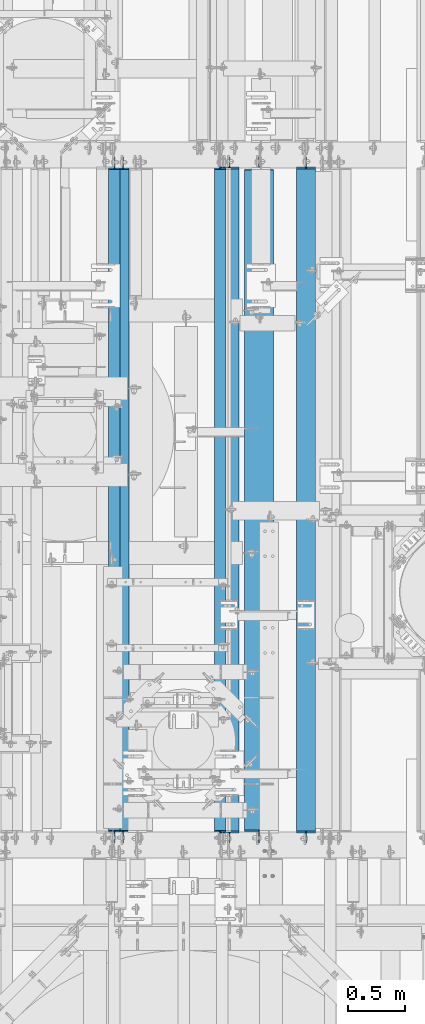
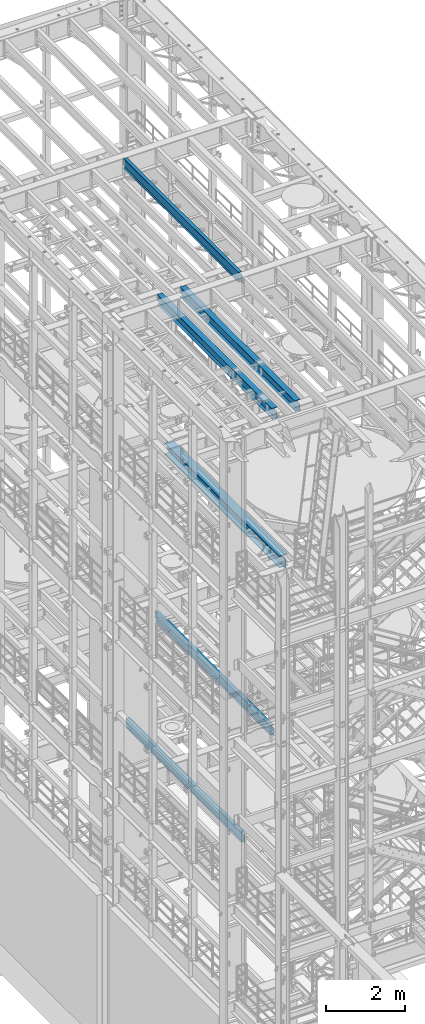
# One storey, part 1030 of 1876: 6 beams, 6 elements without a shape of their own.
"""IFC2X3 building model written with IfcOpenShell, lengths in millimetres."""

from ifc_helpers import new_model, si_unit, frame, origin_with_axes, place, context, subcontext, project, spatial, faceted_brep, material, type_object, element, aggregate, save


model = new_model("IFC2X3")

# Units and contexts
model_context = context("Model", 3, precision=1e-05, world=origin_with_axes())
body_context = subcontext(model_context, "Body", "Model", "MODEL_VIEW")
ifc_project = project(units=[si_unit("LENGTHUNIT", "METRE", prefix="MILLI"), si_unit("AREAUNIT", "SQUARE_METRE"), si_unit("VOLUMEUNIT", "CUBIC_METRE"), si_unit("MASSUNIT", "GRAM", prefix="KILO"), si_unit("TIMEUNIT", "SECOND"), si_unit("PLANEANGLEUNIT", "RADIAN"), si_unit("SOLIDANGLEUNIT", "STERADIAN"), si_unit("THERMODYNAMICTEMPERATUREUNIT", "DEGREE_CELSIUS"), si_unit("LUMINOUSINTENSITYUNIT", "LUMEN")], contexts=[model_context])

# Site, building, storey
site_placement = place(None, origin_with_axes())
site = spatial("IfcSite", under=ifc_project, at=site_placement, CompositionType="ELEMENT")
building_placement = place(site_placement, origin_with_axes())
building = spatial("IfcBuilding", under=site, at=building_placement, Name="Undefined", CompositionType="ELEMENT")
storey_placement = place(building_placement, origin_with_axes())
storey = spatial("IfcBuildingStorey", under=building, at=storey_placement, Name="Undefined", CompositionType="ELEMENT", Elevation=0.0)

# Assembly, beam
assembly_1_placement = place(storey_placement, origin_with_axes())
assembly_1 = element("IfcElementAssembly", 1, at=assembly_1_placement, inside=storey, Name="BEAM", AssemblyPlace="NOTDEFINED", PredefinedType="RIGID_FRAME")
ifc_material = material(Name="STEEL/A992")
beam_type_1 = type_object("IfcBeamType", Name="W12X26", PredefinedType="NOTDEFINED")
beam_1_placement = place(assembly_1_placement, frame((4826.0, 1524.0, 17827.625), z_axis=(0.0, 0.0, 1.0), x_axis=(0.0, 1.0, 0.0)))
beam_1 = element("IfcBeam", 2, at=beam_1_placement, type_object=beam_type_1, material=ifc_material, Name="BEAM", ObjectType="W12X26", context=body_context, shape_type="Brep", body=[
    faceted_brep([(19.8437512414296, -3.17500000000109, -130.175), (19.8437487585795, 3.17499999999927, -130.175), (96.0437824675421, 3.175000000002, -130.175), (96.0437824675423, -3.17499999999745, -130.175), (100.903861985588, 3.175000000002, -131.141729922588), (100.903861985589, -3.17499999999745, -131.141729922588), (105.024038453743, 3.17500000000291, -133.894743823066), (105.024038453744, -3.17499999999654, -133.894743823066), (107.777052354222, 3.17500000000291, -138.01492029122), (107.777052354222, -3.17499999999745, -138.01492029122), (108.743782276811, -3.17499999999654, -142.874999809265), (108.74378227681, 3.17500000000291, -142.874999809265), (108.74375, 3.17500009516311, -146.049999999999), (108.743782276807, 82.5500000000084, -146.05), (108.743782276807, 82.5500000000084, -155.575), (108.743782276814, -82.5500000000029, -155.575), (108.743782276814, -82.5500000000029, -146.05), (108.74375, -3.17499999999995, -146.049999999999), (5969.79375, 82.55, 146.049999999999), (5969.79375, 3.17499999999995, 146.049999999999), (126.20625, 3.17499999999995, 146.049999999999), (126.20625, 82.55, 146.049999999999), (113.506250190735, -3.17499999999995, 111.125000000004), (113.506250190735, 3.17499998562812, 111.125000000004), (19.8437500000002, 3.17499999999995, 111.125000000004), (19.8437500000002, -3.17499999999995, 111.125000000004), (118.36632970878, -3.17499999999995, 112.091729922591), (118.36632970878, 3.17499998547237, 112.091729922591), (122.486506176934, -3.17499999999995, 114.844743823069), (122.486506176934, 3.17499998502694, 114.844743823069), (125.239520077412, -3.17499999999995, 118.964920291222), (125.239520077412, 3.17499998436006, 118.964920291222), (126.20625, -3.17499999999995, 123.824999809269), (126.20625, 3.17499998357312, 123.824999809269), (5969.79375, -82.55, 155.575000000001), (5969.79375, 82.55, 155.575000000001), (126.20625, 82.55, 155.575000000001), (126.20625, -82.55, 155.575000000001), (5969.79375, -82.55, 146.049999999999), (126.20625, -82.55, 146.049999999999), (5969.79375, -3.17499999999995, 146.049999999999), (126.20625, -3.17499999999995, 146.049999999999), (5969.79375, -3.17499999999995, 123.824999809269), (5969.79375, 3.17499999999995, 123.824999809269), (5970.76047992259, -3.17499999999995, 118.964920291222), (5970.76047992259, 3.17499999999995, 118.964920291222), (5973.51349382307, -3.17499999999995, 114.844743823069), (5973.51349382307, 3.17499999999995, 114.844743823069), (5977.63367029122, -3.17499999999995, 112.091729922591), (5977.63367029122, 3.17499999999995, 112.091729922591), (5982.49374980926, -3.17499999999995, 111.125000000004), (5982.49374980926, 3.17499999999995, 111.125000000004), (6076.15625, -3.17499999999995, 111.125000000004), (6076.15625, 3.17499999999995, 111.125000000004), (6076.15625, -3.17499999999995, -130.174999999996), (6076.15625, 3.17499999999995, -130.174999999996), (5999.95624980927, -3.17499999999995, -130.174999999996), (5999.95624980927, 3.17499999999995, -130.174999999996), (5995.09617029122, -3.17499999999995, -131.141729922583), (5995.09617029122, 3.17499999999995, -131.141729922583), (5990.97599382307, -3.17499999999995, -133.894743823061), (5990.97599382307, 3.17499999999995, -133.894743823061), (5988.22297992259, -3.17499999999995, -138.014920291214), (5988.22297992259, 3.17499999999995, -138.014920291214), (5987.25625, -3.17499999999995, -142.874999809261), (5987.25625, 3.17499999999995, -142.874999809261), (5987.25625, -3.17499999999995, -146.049999999999), (5987.25625, -82.55, -146.049999999999), (5987.25625, -82.55, -155.575000000001), (5987.25625, 82.55, -155.575000000001), (5987.25625, 82.55, -146.049999999999), (5987.25625, 3.17499999999995, -146.049999999999)], [[[0, 1, 2, 3]], [[3, 2, 4, 5]], [[5, 4, 6, 7]], [[7, 6, 8, 9]], [[10, 11, 12, 13, 14, 15, 16, 17]], [[9, 8, 11, 10]], [[18, 19, 20, 21]], [[22, 23, 24, 25]], [[26, 27, 23, 22]], [[28, 29, 27, 26]], [[30, 31, 29, 28]], [[32, 33, 31, 30]], [[34, 35, 36, 37]], [[38, 34, 37, 39]], [[40, 38, 39, 41]], [[37, 36, 21, 20, 33, 32, 41, 39]], [[35, 18, 21, 36]], [[34, 38, 40, 42, 43, 19, 18, 35]], [[44, 45, 43, 42]], [[46, 47, 45, 44]], [[48, 49, 47, 46]], [[50, 51, 49, 48]], [[52, 53, 51, 50]], [[53, 52, 54, 55]], [[54, 56, 57, 55]], [[58, 59, 57, 56]], [[60, 61, 59, 58]], [[62, 63, 61, 60]], [[64, 65, 63, 62]], [[66, 67, 68, 69, 70, 71, 65, 64]], [[67, 66, 17, 16]], [[68, 67, 16, 15]], [[69, 68, 15, 14]], [[70, 69, 14, 13]], [[71, 70, 13, 12]], [[6, 4, 2, 1, 24, 23, 27, 29, 31, 33, 20, 19, 43, 45, 47, 49, 51, 53, 55, 57, 59, 61, 63, 65, 71, 12, 11, 8]], [[25, 24, 1, 0]], [[66, 64, 62, 60, 58, 56, 54, 52, 50, 48, 46, 44, 42, 40, 41, 32, 30, 28, 26, 22, 25, 0, 3, 5, 7, 9, 10, 17]]]),
])
aggregate(assembly_1, [beam_1])

assembly_2_placement = place(storey_placement, origin_with_axes())
assembly_2 = element("IfcElementAssembly", 3, at=assembly_2_placement, inside=storey, Name="BEAM", AssemblyPlace="NOTDEFINED", PredefinedType="RIGID_FRAME")
beam_type_2 = type_object("IfcBeamType", Name="W12X16", PredefinedType="NOTDEFINED")
beam_2_placement = place(assembly_2_placement, frame((4743.45, 1524.0, 8001.0), z_axis=(0.0, 0.0, 1.0), x_axis=(0.0, 1.0, 0.0)))
beam_2 = element("IfcBeam", 4, at=beam_2_placement, type_object=beam_type_2, material=ifc_material, Name="BEAM", ObjectType="W12X16", context=body_context, shape_type="Brep", body=[
    faceted_brep([(5980.90625, -3.17499999999995, -146.05), (5980.90625, -50.8, -146.05), (5980.90625, -50.8, -152.4), (5980.90625, 50.8, -152.4), (5980.90625, 50.8, -146.05), (5980.90625, 3.17499999999995, -146.05), (5980.90625, 3.17499999999995, -139.699999809266), (5980.90625, -3.17499999999995, -139.699999809266), (5981.87297992259, 3.17499999999995, -134.839920291221), (5981.87297992259, -3.17499999999995, -134.839920291221), (5984.62599382307, 3.17499999999995, -130.719743823067), (5984.62599382307, -3.17499999999995, -130.719743823067), (5988.74617029122, 3.17499999999995, -127.966729922588), (5988.74617029122, -3.17499999999995, -127.966729922588), (5993.60624980927, 3.17499999999995, -127.000000000001), (5993.60624980927, -3.17499999999995, -127.000000000001), (6076.15625, -3.17499999999995, -126.999999999996), (6076.15625, 3.17499999999995, -126.999999999996), (127.79375, 3.17500000000018, 146.05), (127.79375, 50.8000000000002, 146.05), (5968.20625, 50.8, 146.05), (5968.20625, 3.17499999999995, 146.05), (115.09375, -3.17500000000018, -139.699999809266), (115.09375, 3.17500000000018, -139.699999809266), (115.09375, 3.17500000000018, -146.05), (115.09375, 50.8000000000002, -146.05), (115.09375, 50.8000000000002, -152.4), (115.09375, -50.8000000000002, -152.4), (115.09375, -50.8000000000002, -146.05), (115.09375, -3.17500000000018, -146.05), (114.127020077412, -3.17500000000018, -134.839920291221), (114.127020077412, 3.17500000000018, -134.839920291221), (111.374006176934, -3.17500000000018, -130.719743823067), (111.374006176934, 3.17500000000018, -130.719743823067), (107.25382970878, -3.17500000000018, -127.966729922588), (107.25382970878, 3.17500000000018, -127.966729922588), (102.393750190735, -3.17500000000018, -127.000000000001), (102.393750190735, 3.17500000000018, -127.000000000001), (19.84375, -3.17499999999995, -126.999999999996), (19.84375, 3.17499999999995, -126.999999999996), (19.84375, -3.17500000000018, 114.299999999999), (19.84375, 3.17500000000018, 114.299999999999), (115.093750190735, -3.17500000000018, 114.299999999999), (115.093750190735, 3.17500000000018, 114.299999999999), (119.95382970878, -3.17500000000018, 115.266729922587), (119.95382970878, 3.17500000000018, 115.266729922587), (124.074006176934, -3.17500000000018, 118.019743823065), (124.074006176934, 3.17500000000018, 118.019743823065), (126.827020077412, -3.17500000000018, 122.139920291219), (126.827020077412, 3.17500000000018, 122.139920291219), (127.79375, -3.17500000000018, 126.999999809264), (127.79375, 3.17500000000018, 126.999999809264), (127.79375, -50.8000000000002, 152.4), (127.79375, 50.8000000000002, 152.4), (127.79375, -3.17500000000018, 146.05), (127.79375, -50.8000000000002, 146.05), (5968.20625, -3.17499999999995, 146.05), (5968.20625, -50.8, 146.05), (5968.20625, -50.8, 152.4), (5968.20625, 50.8, 152.4), (5968.20625, -3.17499999999995, 126.999999809264), (5968.20625, 3.17499999999995, 126.999999809264), (5969.17297992259, -3.17499999999995, 122.139920291219), (5969.17297992259, 3.17499999999995, 122.139920291219), (5971.92599382307, -3.17499999999995, 118.019743823065), (5971.92599382307, 3.17499999999995, 118.019743823065), (5976.04617029122, -3.17499999999995, 115.266729922587), (5976.04617029122, 3.17499999999995, 115.266729922587), (5980.90624980927, -3.17499999999995, 114.299999999999), (5980.90624980927, 3.17499999999995, 114.299999999999), (6076.15625, -3.17499999999995, 114.299999999999), (6076.15625, 3.17499999999995, 114.299999999999)], [[[0, 1, 2, 3, 4, 5, 6, 7]], [[7, 6, 8, 9]], [[9, 8, 10, 11]], [[11, 10, 12, 13]], [[13, 12, 14, 15]], [[16, 15, 14, 17]], [[18, 19, 20, 21]], [[22, 23, 24, 25, 26, 27, 28, 29]], [[30, 31, 23, 22]], [[32, 33, 31, 30]], [[34, 35, 33, 32]], [[36, 37, 35, 34]], [[38, 39, 37, 36]], [[40, 41, 39, 38]], [[42, 43, 41, 40]], [[44, 45, 43, 42]], [[46, 47, 45, 44]], [[48, 49, 47, 46]], [[50, 51, 49, 48]], [[52, 53, 19, 18, 51, 50, 54, 55]], [[55, 54, 56, 57]], [[52, 55, 57, 58]], [[53, 52, 58, 59]], [[19, 53, 59, 20]], [[58, 57, 56, 60, 61, 21, 20, 59]], [[62, 63, 61, 60]], [[64, 65, 63, 62]], [[66, 67, 65, 64]], [[68, 69, 67, 66]], [[70, 71, 69, 68]], [[71, 70, 16, 17]], [[12, 10, 8, 6, 5, 24, 23, 31, 33, 35, 37, 39, 41, 43, 45, 47, 49, 51, 18, 21, 61, 63, 65, 67, 69, 71, 17, 14]], [[25, 24, 5, 4]], [[26, 25, 4, 3]], [[27, 26, 3, 2]], [[28, 27, 2, 1]], [[29, 28, 1, 0]], [[70, 68, 66, 64, 62, 60, 56, 54, 50, 48, 46, 44, 42, 40, 38, 36, 34, 32, 30, 22, 29, 0, 7, 9, 11, 13, 15, 16]]]),
])
aggregate(assembly_2, [beam_2])

assembly_3_placement = place(storey_placement, origin_with_axes())
assembly_3 = element("IfcElementAssembly", 5, at=assembly_3_placement, inside=storey, Name="BEAM", AssemblyPlace="NOTDEFINED", PredefinedType="RIGID_FRAME")
beam_3_placement = place(assembly_3_placement, frame((3810.0, 1524.0, 22402.8), z_axis=(0.0, 0.0, 1.0), x_axis=(0.0, 1.0, 0.0)))
beam_3 = element("IfcBeam", 6, at=beam_3_placement, type_object=beam_type_2, material=ifc_material, Name="BEAM", ObjectType="W12X16", context=body_context, shape_type="Brep", body=[
    faceted_brep([(19.84375, -3.17499999999995, -126.999999999996), (19.84375, 3.17499999999995, -126.999999999996), (102.393750190735, 3.17500000000018, -127.000000000001), (102.393750190735, -3.17500000000018, -127.000000000001), (107.25382970878, 3.17500000000018, -127.966729922588), (107.25382970878, -3.17500000000018, -127.966729922588), (111.374006176934, 3.17500000000018, -130.719743823067), (111.374006176934, -3.17500000000018, -130.719743823067), (114.127020077412, 3.17500000000018, -134.839920291221), (114.127020077412, -3.17500000000018, -134.839920291221), (115.09375, -3.17500000000018, -139.699999809266), (115.09375, 3.17500000000018, -139.699999809266), (115.09375, 3.17500000000018, -146.05), (115.09375, 50.8000000000002, -146.05), (115.09375, 50.8000000000002, -152.4), (115.09375, -50.8000000000002, -152.4), (115.09375, -50.8000000000002, -146.05), (115.09375, -3.17500000000018, -146.05), (127.79375, 3.17500000000018, 146.05), (127.79375, 50.8000000000002, 146.05), (5968.20625, 50.8, 146.05), (5968.20625, 3.17499999999995, 146.05), (115.093750190735, -3.17500000000018, 114.299999999999), (115.093750190735, 3.17500000000018, 114.299999999999), (19.84375, 3.17500000000018, 114.299999999999), (19.84375, -3.17500000000018, 114.299999999999), (119.95382970878, -3.17500000000018, 115.266729922587), (119.95382970878, 3.17500000000018, 115.266729922587), (124.074006176934, -3.17500000000018, 118.019743823065), (124.074006176934, 3.17500000000018, 118.019743823065), (126.827020077412, -3.17500000000018, 122.139920291219), (126.827020077412, 3.17500000000018, 122.139920291219), (127.79375, -3.17500000000018, 126.999999809264), (127.79375, 3.17500000000018, 126.999999809264), (127.79375, 50.8000000000002, 152.4), (127.79375, -50.8000000000002, 152.4), (5968.20625, -50.8, 152.4), (5968.20625, 50.8, 152.4), (127.79375, -50.8000000000002, 146.05), (5968.20625, -50.8, 146.05), (127.79375, -3.17500000000018, 146.05), (5968.20625, -3.17499999999995, 146.05), (5968.20625, -3.17499999999995, 126.999999809264), (5968.20625, 3.17499999999995, 126.999999809264), (5969.17297992259, -3.17499999999995, 122.139920291219), (5969.17297992259, 3.17499999999995, 122.139920291219), (5971.92599382307, -3.17499999999995, 118.019743823065), (5971.92599382307, 3.17499999999995, 118.019743823065), (5976.04617029122, -3.17499999999995, 115.266729922587), (5976.04617029122, 3.17499999999995, 115.266729922587), (5980.90624980927, -3.17499999999995, 114.299999999999), (5980.90624980927, 3.17499999999995, 114.299999999999), (6076.15625, -3.17499999999995, 114.299999999999), (6076.15625, 3.17499999999995, 114.299999999999), (6076.15625, -3.17499999999995, -126.999999999996), (6076.15625, 3.17499999999995, -126.999999999996), (5993.60624980927, -3.17499999999995, -127.000000000001), (5993.60624980927, 3.17499999999995, -127.000000000001), (5988.74617029122, -3.17499999999995, -127.966729922588), (5988.74617029122, 3.17499999999995, -127.966729922588), (5984.62599382307, -3.17499999999995, -130.719743823067), (5984.62599382307, 3.17499999999995, -130.719743823067), (5981.87297992259, -3.17499999999995, -134.839920291221), (5981.87297992259, 3.17499999999995, -134.839920291221), (5980.90625, -3.17499999999995, -139.699999809266), (5980.90625, 3.17499999999995, -139.699999809266), (5980.90625, -3.17499999999995, -146.05), (5980.90625, -50.8, -146.05), (5980.90625, -50.8, -152.4), (5980.90625, 50.8, -152.4), (5980.90625, 50.8, -146.05), (5980.90625, 3.17499999999995, -146.05)], [[[0, 1, 2, 3]], [[3, 2, 4, 5]], [[5, 4, 6, 7]], [[7, 6, 8, 9]], [[10, 11, 12, 13, 14, 15, 16, 17]], [[9, 8, 11, 10]], [[18, 19, 20, 21]], [[22, 23, 24, 25]], [[26, 27, 23, 22]], [[28, 29, 27, 26]], [[30, 31, 29, 28]], [[32, 33, 31, 30]], [[34, 35, 36, 37]], [[35, 38, 39, 36]], [[38, 40, 41, 39]], [[35, 34, 19, 18, 33, 32, 40, 38]], [[19, 34, 37, 20]], [[36, 39, 41, 42, 43, 21, 20, 37]], [[44, 45, 43, 42]], [[46, 47, 45, 44]], [[48, 49, 47, 46]], [[50, 51, 49, 48]], [[52, 53, 51, 50]], [[53, 52, 54, 55]], [[54, 56, 57, 55]], [[58, 59, 57, 56]], [[60, 61, 59, 58]], [[62, 63, 61, 60]], [[64, 65, 63, 62]], [[66, 67, 68, 69, 70, 71, 65, 64]], [[17, 16, 67, 66]], [[16, 15, 68, 67]], [[15, 14, 69, 68]], [[14, 13, 70, 69]], [[13, 12, 71, 70]], [[59, 61, 63, 65, 71, 12, 11, 8, 6, 4, 2, 1, 24, 23, 27, 29, 31, 33, 18, 21, 43, 45, 47, 49, 51, 53, 55, 57]], [[25, 24, 1, 0]], [[52, 50, 48, 46, 44, 42, 41, 40, 32, 30, 28, 26, 22, 25, 0, 3, 5, 7, 9, 10, 17, 66, 64, 62, 60, 58, 56, 54]]]),
])
aggregate(assembly_3, [beam_3])

assembly_4_placement = place(storey_placement, origin_with_axes())
assembly_4 = element("IfcElementAssembly", 7, at=assembly_4_placement, inside=storey, Name="BEAM", AssemblyPlace="NOTDEFINED", PredefinedType="RIGID_FRAME")
beam_4_placement = place(assembly_4_placement, frame((3886.2, 1524.0, 4978.4), z_axis=(0.0, 0.0, 1.0), x_axis=(0.0, 1.0, 0.0)))
beam_4 = element("IfcBeam", 8, at=beam_4_placement, type_object=beam_type_2, material=ifc_material, Name="BEAM", ObjectType="W12X16", context=body_context, shape_type="Brep", body=[
    faceted_brep([(19.84375, -3.17499999999995, -126.999999999996), (19.84375, 3.17499999999995, -126.999999999996), (102.393750190735, 3.17500000000018, -127.000000000001), (102.393750190735, -3.17500000000018, -127.000000000001), (107.25382970878, 3.17500000000018, -127.966729922588), (107.25382970878, -3.17500000000018, -127.966729922588), (111.374006176934, 3.17500000000018, -130.719743823067), (111.374006176934, -3.17500000000018, -130.719743823067), (114.127020077412, 3.17500000000018, -134.839920291221), (114.127020077412, -3.17500000000018, -134.839920291221), (115.09375, -3.17500000000018, -139.699999809266), (115.09375, 3.17500000000018, -139.699999809266), (115.09375, 3.17500000000018, -146.05), (115.09375, 50.8000000000002, -146.05), (115.09375, 50.8000000000002, -152.4), (115.09375, -50.8000000000002, -152.4), (115.09375, -50.8000000000002, -146.05), (115.09375, -3.17500000000018, -146.05), (127.79375, 3.17500000000018, 146.05), (127.79375, 50.8000000000002, 146.05), (5968.20625, 50.8, 146.05), (5968.20625, 3.17499999999995, 146.05), (115.093750190735, -3.17500000000018, 114.299999999999), (115.093750190735, 3.17500000000018, 114.299999999999), (19.84375, 3.17500000000018, 114.299999999999), (19.84375, -3.17500000000018, 114.299999999999), (119.95382970878, -3.17500000000018, 115.266729922587), (119.95382970878, 3.17500000000018, 115.266729922587), (124.074006176934, -3.17500000000018, 118.019743823065), (124.074006176934, 3.17500000000018, 118.019743823065), (126.827020077412, -3.17500000000018, 122.139920291219), (126.827020077412, 3.17500000000018, 122.139920291219), (127.79375, -3.17500000000018, 126.999999809264), (127.79375, 3.17500000000018, 126.999999809264), (127.79375, 50.8000000000002, 152.4), (127.79375, -50.8000000000002, 152.4), (5968.20625, -50.8, 152.4), (5968.20625, 50.8, 152.4), (127.79375, -50.8000000000002, 146.05), (5968.20625, -50.8, 146.05), (127.79375, -3.17500000000018, 146.05), (5968.20625, -3.17499999999995, 146.05), (5968.20625, -3.17499999999995, 126.999999809264), (5968.20625, 3.17499999999995, 126.999999809264), (5969.17297992259, -3.17499999999995, 122.139920291219), (5969.17297992259, 3.17499999999995, 122.139920291219), (5971.92599382307, -3.17499999999995, 118.019743823065), (5971.92599382307, 3.17499999999995, 118.019743823065), (5976.04617029122, -3.17499999999995, 115.266729922587), (5976.04617029122, 3.17499999999995, 115.266729922587), (5980.90624980927, -3.17499999999995, 114.299999999999), (5980.90624980927, 3.17499999999995, 114.299999999999), (6076.15625, -3.17499999999995, 114.299999999999), (6076.15625, 3.17499999999995, 114.299999999999), (6076.15625, -3.17499999999995, -126.999999999996), (6076.15625, 3.17499999999995, -126.999999999996), (5993.60624980927, -3.17499999999995, -127.000000000001), (5993.60624980927, 3.17499999999995, -127.000000000001), (5988.74617029122, -3.17499999999995, -127.966729922588), (5988.74617029122, 3.17499999999995, -127.966729922588), (5984.62599382307, -3.17499999999995, -130.719743823067), (5984.62599382307, 3.17499999999995, -130.719743823067), (5981.87297992259, -3.17499999999995, -134.839920291221), (5981.87297992259, 3.17499999999995, -134.839920291221), (5980.90625, -3.17499999999995, -139.699999809266), (5980.90625, 3.17499999999995, -139.699999809266), (5980.90625, -3.17499999999995, -146.05), (5980.90625, -50.8, -146.05), (5980.90625, -50.8, -152.4), (5980.90625, 50.8, -152.4), (5980.90625, 50.8, -146.05), (5980.90625, 3.17499999999995, -146.05)], [[[0, 1, 2, 3]], [[3, 2, 4, 5]], [[5, 4, 6, 7]], [[7, 6, 8, 9]], [[10, 11, 12, 13, 14, 15, 16, 17]], [[9, 8, 11, 10]], [[18, 19, 20, 21]], [[22, 23, 24, 25]], [[26, 27, 23, 22]], [[28, 29, 27, 26]], [[30, 31, 29, 28]], [[32, 33, 31, 30]], [[34, 35, 36, 37]], [[35, 38, 39, 36]], [[38, 40, 41, 39]], [[35, 34, 19, 18, 33, 32, 40, 38]], [[19, 34, 37, 20]], [[36, 39, 41, 42, 43, 21, 20, 37]], [[44, 45, 43, 42]], [[46, 47, 45, 44]], [[48, 49, 47, 46]], [[50, 51, 49, 48]], [[52, 53, 51, 50]], [[53, 52, 54, 55]], [[54, 56, 57, 55]], [[58, 59, 57, 56]], [[60, 61, 59, 58]], [[62, 63, 61, 60]], [[64, 65, 63, 62]], [[66, 67, 68, 69, 70, 71, 65, 64]], [[17, 16, 67, 66]], [[16, 15, 68, 67]], [[15, 14, 69, 68]], [[14, 13, 70, 69]], [[13, 12, 71, 70]], [[59, 61, 63, 65, 71, 12, 11, 8, 6, 4, 2, 1, 24, 23, 27, 29, 31, 33, 18, 21, 43, 45, 47, 49, 51, 53, 55, 57]], [[25, 24, 1, 0]], [[52, 50, 48, 46, 44, 42, 41, 40, 32, 30, 28, 26, 22, 25, 0, 3, 5, 7, 9, 10, 17, 66, 64, 62, 60, 58, 56, 54]]]),
])
aggregate(assembly_4, [beam_4])

assembly_5_placement = place(storey_placement, origin_with_axes())
assembly_5 = element("IfcElementAssembly", 9, at=assembly_5_placement, inside=storey, Name="BEAM", AssemblyPlace="NOTDEFINED", PredefinedType="RIGID_FRAME")
beam_type_3 = type_object("IfcBeamType", Name="W12X30", PredefinedType="NOTDEFINED")
beam_5_placement = place(assembly_5_placement, frame((5502.275, 1524.0, 17826.0375), z_axis=(0.0, 0.0, 1.0), x_axis=(0.0, 1.0, 0.0)))
beam_5 = element("IfcBeam", 10, at=beam_5_placement, type_object=beam_type_3, material=ifc_material, Name="BEAM", ObjectType="W12X30", context=body_context, shape_type="Brep", body=[
    faceted_brep([(19.8437500000002, -3.17500000000018, -131.762499999993), (19.8437500000002, 3.17500000000018, -131.762499999993), (96.043750190735, 3.17500002451106, -131.762499999993), (96.043750190735, -3.17500000000018, -131.762499999993), (100.90382970878, 3.17500002466841, -132.729229922581), (100.90382970878, -3.17500000000018, -132.729229922581), (105.024006176934, 3.17500002511588, -135.482243823059), (105.024006176934, -3.17500000000018, -135.482243823059), (107.777020077412, 3.17500002578436, -139.602420291212), (107.777020077412, -3.17500000000018, -139.602420291212), (108.74375, -3.17500000000018, -144.462499809259), (108.74375, 3.17500002657198, -144.462499809259), (108.74375, 3.17500009516311, -146.049999999999), (108.743782276807, 82.5500000000084, -146.05), (108.74375, 82.5500000000002, -157.162499999999), (108.74375, -82.5500000000002, -157.162499999999), (108.743782276814, -82.5500000000029, -146.05), (108.74375, -3.17499999999995, -146.049999999999), (5969.79375, 82.55, 146.049999999999), (5969.79375, 3.17499999999995, 146.049999999999), (126.20625, 3.17499999999995, 146.049999999999), (126.20625, 82.55, 146.049999999999), (113.506250190735, -3.17500000000018, 112.712500000005), (113.506250190735, 3.17499998541371, 112.712500000005), (19.8437500000002, 3.17500000000018, 112.712500000005), (19.8437500000002, -3.17500000000018, 112.712500000005), (118.36632970878, -3.17500000000018, 113.679229922593), (118.36632970878, 3.17499998525818, 113.679229922593), (122.486506176934, -3.17500000000018, 116.43224382307), (122.486506176934, 3.17499998481253, 116.43224382307), (125.239520077412, -3.17500000000018, 120.552420291224), (125.239520077412, 3.17499998414587, 120.552420291224), (126.20625, -3.17500000000018, 125.41249980927), (126.20625, 3.17499998335916, 125.41249980927), (5969.79375, -82.5500000000002, 157.162499999999), (5969.79375, 82.5500000000002, 157.162499999999), (126.20625, 82.5500000000002, 157.162499999999), (126.20625, -82.5500000000002, 157.162499999999), (5969.79375, -82.55, 146.049999999999), (126.20625, -82.55, 146.049999999999), (5969.79375, -3.17499999999995, 146.049999999999), (126.20625, -3.17499999999995, 146.049999999999), (5969.79375, -3.17500000000018, 125.41249980927), (5969.79375, 3.17500000000018, 125.41249980927), (5970.76047992259, -3.17500000000018, 120.552420291224), (5970.76047992259, 3.17500000000018, 120.552420291224), (5973.51349382307, -3.17500000000018, 116.43224382307), (5973.51349382307, 3.17500000000018, 116.43224382307), (5977.63367029122, -3.17500000000018, 113.679229922593), (5977.63367029122, 3.17500000000018, 113.679229922593), (5982.49374980926, -3.17500000000018, 112.712500000005), (5982.49374980926, 3.17500000000018, 112.712500000005), (6076.15625, -3.17500000000018, 112.712500000005), (6076.15625, 3.17500000000018, 112.712500000005), (6076.15625, -3.17500000000018, -131.762499999993), (6076.15625, 3.17500000000018, -131.762499999993), (5999.95624980927, -3.17500000000018, -131.762499999993), (5999.95624980927, 3.17500000000018, -131.762499999993), (5995.09617029122, -3.17500000000018, -132.729229922581), (5995.09617029122, 3.17500000000018, -132.729229922581), (5990.97599382307, -3.17500000000018, -135.482243823059), (5990.97599382307, 3.17500000000018, -135.482243823059), (5988.22297992259, -3.17500000000018, -139.602420291212), (5988.22297992259, 3.17500000000018, -139.602420291212), (5987.25625, -3.17500000000018, -144.462499809259), (5987.25625, 3.17500000000018, -144.462499809259), (5987.25625, -3.17499999999995, -146.049999999999), (5987.25625, -82.55, -146.049999999999), (5987.25625, -82.5500000000002, -157.162499999999), (5987.25625, 82.5500000000002, -157.162499999999), (5987.25625, 82.55, -146.049999999999), (5987.25625, 3.17499999999995, -146.049999999999)], [[[0, 1, 2, 3]], [[3, 2, 4, 5]], [[5, 4, 6, 7]], [[7, 6, 8, 9]], [[10, 11, 12, 13, 14, 15, 16, 17]], [[9, 8, 11, 10]], [[18, 19, 20, 21]], [[22, 23, 24, 25]], [[26, 27, 23, 22]], [[28, 29, 27, 26]], [[30, 31, 29, 28]], [[32, 33, 31, 30]], [[34, 35, 36, 37]], [[38, 34, 37, 39]], [[40, 38, 39, 41]], [[37, 36, 21, 20, 33, 32, 41, 39]], [[35, 18, 21, 36]], [[34, 38, 40, 42, 43, 19, 18, 35]], [[44, 45, 43, 42]], [[46, 47, 45, 44]], [[48, 49, 47, 46]], [[50, 51, 49, 48]], [[52, 53, 51, 50]], [[53, 52, 54, 55]], [[54, 56, 57, 55]], [[58, 59, 57, 56]], [[60, 61, 59, 58]], [[62, 63, 61, 60]], [[64, 65, 63, 62]], [[66, 67, 68, 69, 70, 71, 65, 64]], [[67, 66, 17, 16]], [[68, 67, 16, 15]], [[69, 68, 15, 14]], [[70, 69, 14, 13]], [[71, 70, 13, 12]], [[6, 4, 2, 1, 24, 23, 27, 29, 31, 33, 20, 19, 43, 45, 47, 49, 51, 53, 55, 57, 59, 61, 63, 65, 71, 12, 11, 8]], [[25, 24, 1, 0]], [[66, 64, 62, 60, 58, 56, 54, 52, 50, 48, 46, 44, 42, 40, 41, 32, 30, 28, 26, 22, 25, 0, 3, 5, 7, 9, 10, 17]]]),
])
aggregate(assembly_5, [beam_5])

assembly_6_placement = place(storey_placement, origin_with_axes())
assembly_6 = element("IfcElementAssembly", 11, at=assembly_6_placement, inside=storey, Name="BEAM", AssemblyPlace="NOTDEFINED", PredefinedType="RIGID_FRAME")
beam_type_4 = type_object("IfcBeamType", Name="W14X68", PredefinedType="NOTDEFINED")
beam_6_placement = place(assembly_6_placement, frame((5086.35, 1524.0, 13131.8), z_axis=(0.0, 0.0, 1.0), x_axis=(0.0, 1.0, 0.0)))
beam_6 = element("IfcBeam", 12, at=beam_6_placement, type_object=beam_type_4, material=ifc_material, Name="BEAM", ObjectType="W14X68", context=body_context, shape_type="Brep", body=[
    faceted_brep([(19.8437500000002, -5.55624999999964, -152.4), (19.8437500000002, 5.55624999999964, -152.4), (108.743750190735, 5.55624999999964, -152.4), (108.743750190735, -5.55624999999964, -152.4), (113.60382970878, 5.55624999999964, -153.366729922587), (113.60382970878, -5.55624999999964, -153.366729922587), (117.724006176934, 5.55624999999964, -156.119743823065), (117.724006176934, -5.55624999999964, -156.119743823065), (119.481487166617, -127.0, -158.75), (119.481487166617, -5.55624999999964, -158.75), (119.481487166617, 5.55624999999964, -158.75), (119.481487166617, 127.0, -158.75), (120.477020077412, 127.0, -160.239920291218), (120.477020077412, -127.0, -160.239920291218), (121.44375, -127.0, -165.099999809265), (121.44375, 127.0, -165.099999809265), (121.443749999999, 127.0, -177.799999999999), (121.443749999999, -127.0, -177.799999999999), (5961.85625, 127.0, 158.75), (5961.85625, 5.55624999999964, 158.75), (134.143749999999, 5.55624999999964, 158.75), (134.143749999999, 127.0, 158.75), (121.443750190735, -5.55624999999964, 133.35), (121.443750190735, 5.55624999999964, 133.35), (19.8437500000002, 5.55624999999964, 133.35), (19.8437500000002, -5.55624999999964, 133.35), (126.30382970878, -5.55624999999964, 134.316729922588), (126.30382970878, 5.55624999999964, 134.316729922588), (130.424006176934, -5.55624999999964, 137.069743823065), (130.424006176934, 5.55624999999964, 137.069743823065), (133.177020077412, -5.55624999999964, 141.189920291219), (133.177020077412, 5.55624999999964, 141.189920291219), (134.14375, -5.55624999999964, 146.049999809266), (134.14375, 5.55624999999964, 146.049999809266), (5961.85625, -127.0, 177.799999999999), (5961.85625, 127.0, 177.799999999999), (134.143749999999, 127.0, 177.799999999999), (134.143749999999, -127.0, 177.799999999999), (5961.85625, -127.0, 158.75), (134.143749999999, -127.0, 158.75), (5961.85625, -5.55624999999964, 158.75), (134.143749999999, -5.55624999999964, 158.75), (5961.85625, -5.55624999999964, 146.049999809266), (5961.85625, 5.55624999999964, 146.049999809266), (5962.82297992259, -5.55624999999964, 141.189920291219), (5962.82297992259, 5.55624999999964, 141.189920291219), (5965.57599382307, -5.55624999999964, 137.069743823065), (5965.57599382307, 5.55624999999964, 137.069743823065), (5969.69617029122, -5.55624999999964, 134.316729922588), (5969.69617029122, 5.55624999999964, 134.316729922588), (5974.55624980926, -5.55624999999964, 133.35), (5974.55624980926, 5.55624999999964, 133.35), (6076.15625, -5.55624999999964, 133.35), (6076.15625, 5.55624999999964, 133.35), (6076.15625, -5.55624999999964, -139.699999999999), (6076.15625, 5.55624999999964, -139.699999999999), (5980.90624980927, -5.55624999999964, -139.699999999999), (5980.90624980927, 5.55624999999964, -139.699999999999), (5976.04617029122, -5.55624999999964, -140.666729922586), (5976.04617029122, 5.55624999999964, -140.666729922586), (5971.92599382307, -5.55624999999964, -143.419743823064), (5971.92599382307, 5.55624999999964, -143.419743823064), (5969.17297992259, -5.55624999999964, -147.539920291218), (5969.17297992259, 5.55624999999964, -147.539920291218), (5968.20625, -5.55624999999964, -152.399999809264), (5968.20625, 5.55624999999964, -152.399999809264), (5968.20625, -5.55624999999964, -158.75), (5968.20625, -127.0, -158.75), (5968.20625, -127.0, -177.799999999999), (5968.20625, 127.0, -177.799999999999), (5968.20625, 127.0, -158.75), (5968.20625, 5.55624999999964, -158.75)], [[[0, 1, 2, 3]], [[3, 2, 4, 5]], [[5, 4, 6, 7]], [[8, 9, 7, 6, 10, 11, 12, 13]], [[14, 15, 16, 17]], [[13, 12, 15, 14]], [[18, 19, 20, 21]], [[22, 23, 24, 25]], [[26, 27, 23, 22]], [[28, 29, 27, 26]], [[30, 31, 29, 28]], [[32, 33, 31, 30]], [[34, 35, 36, 37]], [[38, 34, 37, 39]], [[40, 38, 39, 41]], [[37, 36, 21, 20, 33, 32, 41, 39]], [[35, 18, 21, 36]], [[34, 38, 40, 42, 43, 19, 18, 35]], [[44, 45, 43, 42]], [[46, 47, 45, 44]], [[48, 49, 47, 46]], [[50, 51, 49, 48]], [[52, 53, 51, 50]], [[53, 52, 54, 55]], [[54, 56, 57, 55]], [[58, 59, 57, 56]], [[60, 61, 59, 58]], [[62, 63, 61, 60]], [[64, 65, 63, 62]], [[66, 67, 68, 69, 70, 71, 65, 64]], [[69, 68, 17, 16]], [[11, 70, 69, 16, 15, 12]], [[71, 70, 11, 10]], [[4, 2, 1, 24, 23, 27, 29, 31, 33, 20, 19, 43, 45, 47, 49, 51, 53, 55, 57, 59, 61, 63, 65, 71, 10, 6]], [[25, 24, 1, 0]], [[66, 64, 62, 60, 58, 56, 54, 52, 50, 48, 46, 44, 42, 40, 41, 32, 30, 28, 26, 22, 25, 0, 3, 5, 7, 9]], [[67, 66, 9, 8]], [[68, 67, 8, 13, 14, 17]]]),
])
aggregate(assembly_6, [beam_6])

save(model, "model.ifc")
